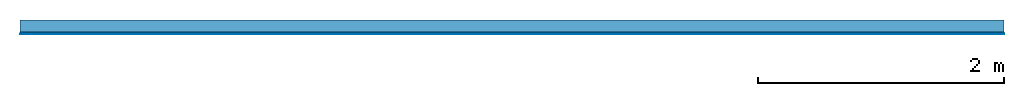
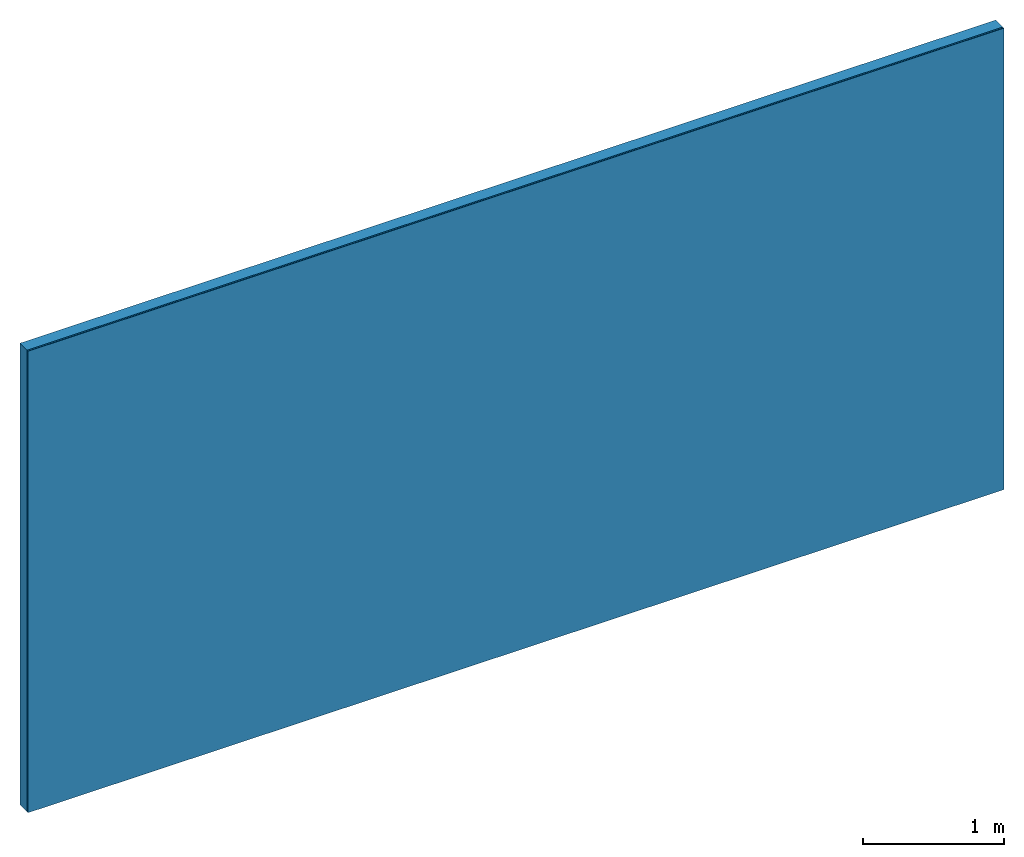
# One storey: 2 plates, 1 member, 1 element without a shape of its own.
"""IFC4 building model written with IfcOpenShell, lengths in metres."""

from ifc_helpers import new_model, si_unit, derived_unit, direction, frame, frame_2d, origin, place, context, project, spatial, rectangle, extrude, material, layer, layer_set, type_object, element, aggregate, save


model = new_model("IFC4")

# Units and contexts
plan_context = context("Plan", 3, precision=1e-05, world=origin(), true_north=direction((0.0, 1.0)))
model_context = context("Model", 3, precision=1e-05, world=origin(), true_north=direction((0.0, 1.0)))
ifc_project = project(units=[si_unit("LENGTHUNIT", "METRE"), derived_unit("SOUNDPRESSUREUNIT", [(si_unit("PRESSUREUNIT", "PASCAL", prefix="MICRO"), 0)]), si_unit("ENERGYUNIT", "JOULE", prefix="MEGA"), si_unit("MASSUNIT", "GRAM", prefix="KILO"), derived_unit("THERMALTRANSMITTANCEUNIT", [(si_unit("POWERUNIT", "WATT"), 1), (si_unit("AREAUNIT", "SQUARE_METRE"), -1), (si_unit("THERMODYNAMICTEMPERATUREUNIT", "KELVIN"), -1)]), derived_unit("AREADENSITYUNIT", [(si_unit("MASSUNIT", "GRAM", prefix="KILO"), 1), (si_unit("AREAUNIT", "SQUARE_METRE"), -1)]), derived_unit("USERDEFINED", [(si_unit("ENERGYUNIT", "JOULE", prefix="MEGA"), 1), (si_unit("AREAUNIT", "SQUARE_METRE"), -1)])], contexts=[plan_context, model_context])

# Site, building, storey
site = spatial("IfcSite", under=ifc_project)
building_placement = place(None, origin())
building = spatial("IfcBuilding", under=site, at=building_placement)
storey_placement = place(building_placement, origin())
storey = spatial("IfcBuildingStorey", under=building, at=storey_placement)

# Wall, member, plates
ifc_layer_1 = layer(None, 0.1, Name="Support")
ifc_material_1 = material(Name="of the art")
ifc_layer_2 = layer(ifc_material_1, 0.0, Name="Bond")
ifc_material_2 = material(Name="Plasterboard type A", Category="03.008")
ifc_layer_3 = layer(ifc_material_2, 0.0125, Name="1st layer")
ifc_material_3 = material(Category="04.001")
ifc_layer_4 = layer(ifc_material_3, 0.003, Name="Surface")
ifc_layer_set = layer_set([ifc_layer_1, ifc_layer_2, ifc_layer_3, ifc_layer_4])
wall_type = type_object("IfcWallType", Name="C0352", PredefinedType="NOTDEFINED", material=ifc_layer_set)
wall_placement = place(None, frame((0.0, 0.0, 0.0), z_axis=(0.0, -1.0, 0.0), x_axis=(1.0, 0.0, 0.0)))
wall = element("IfcWall", 1, at=wall_placement, inside=storey, type_object=wall_type, material=ifc_layer_set, Name="Wall #1")
ifc_material_4 = material(Name="Solid timber panel")
member_placement = place(wall_placement, origin())
member = element("IfcMember", 2, at=member_placement, material=ifc_material_4, Name="Support", context=plan_context, shape_type="SweptSolid", body=[
    extrude(rectangle(XDim=1.0, YDim=0.1, at=frame_2d((0.5, 0.05), x_axis=(1.0, 0.0))), frame((0.0, 4.0, 0.0), z_axis=(0.0, -1.0, 0.0), x_axis=(1.0, 0.0, 0.0)), (0.0, 0.0, 1.0), 4.0),
    extrude(rectangle(XDim=1.0, YDim=0.1, at=frame_2d((0.5, 0.05), x_axis=(1.0, 0.0))), frame((1.0, 4.0, 0.0), z_axis=(0.0, -1.0, 0.0), x_axis=(1.0, 0.0, 0.0)), (0.0, 0.0, 1.0), 4.0),
    extrude(rectangle(XDim=1.0, YDim=0.1, at=frame_2d((0.5, 0.05), x_axis=(1.0, 0.0))), frame((2.0, 4.0, 0.0), z_axis=(0.0, -1.0, 0.0), x_axis=(1.0, 0.0, 0.0)), (0.0, 0.0, 1.0), 4.0),
    extrude(rectangle(XDim=1.0, YDim=0.1, at=frame_2d((0.5, 0.05), x_axis=(1.0, 0.0))), frame((3.0, 4.0, 0.0), z_axis=(0.0, -1.0, 0.0), x_axis=(1.0, 0.0, 0.0)), (0.0, 0.0, 1.0), 4.0),
    extrude(rectangle(XDim=1.0, YDim=0.1, at=frame_2d((0.5, 0.05), x_axis=(1.0, 0.0))), frame((4.0, 4.0, 0.0), z_axis=(0.0, -1.0, 0.0), x_axis=(1.0, 0.0, 0.0)), (0.0, 0.0, 1.0), 4.0),
    extrude(rectangle(XDim=1.0, YDim=0.1, at=frame_2d((0.5, 0.05), x_axis=(1.0, 0.0))), frame((5.0, 4.0, 0.0), z_axis=(0.0, -1.0, 0.0), x_axis=(1.0, 0.0, 0.0)), (0.0, 0.0, 1.0), 4.0),
    extrude(rectangle(XDim=1.0, YDim=0.1, at=frame_2d((0.5, 0.05), x_axis=(1.0, 0.0))), frame((6.0, 4.0, 0.0), z_axis=(0.0, -1.0, 0.0), x_axis=(1.0, 0.0, 0.0)), (0.0, 0.0, 1.0), 4.0),
    extrude(rectangle(XDim=1.0, YDim=0.1, at=frame_2d((0.5, 0.05), x_axis=(1.0, 0.0))), frame((7.0, 4.0, 0.0), z_axis=(0.0, -1.0, 0.0), x_axis=(1.0, 0.0, 0.0)), (0.0, 0.0, 1.0), 4.0),
])
plate_1_placement = place(wall_placement, origin())
plate_1 = element("IfcPlate", 3, at=plate_1_placement, material=ifc_material_2, Name="1st layer", context=plan_context, shape_type="SweptSolid", body=[
    extrude(rectangle(XDim=8.0, YDim=4.0, at=frame_2d((4.0, 2.0), x_axis=(1.0, 0.0))), frame((0.0, 0.0, 0.1), z_axis=(0.0, 0.0, 1.0), x_axis=(1.0, 0.0, 0.0)), (0.0, 0.0, 1.0), 0.0125),
])
plate_2_placement = place(wall_placement, origin())
plate_2 = element("IfcPlate", 4, at=plate_2_placement, material=ifc_material_3, Name="Surface", context=plan_context, shape_type="SweptSolid", body=[
    extrude(rectangle(XDim=8.0, YDim=4.0, at=frame_2d((4.0, 2.0), x_axis=(1.0, 0.0))), frame((0.0, 0.0, 0.1125), z_axis=(0.0, 0.0, 1.0), x_axis=(1.0, 0.0, 0.0)), (0.0, 0.0, 1.0), 0.003),
])
aggregate(wall, [member, plate_1, plate_2])

save(model, "model.ifc")
